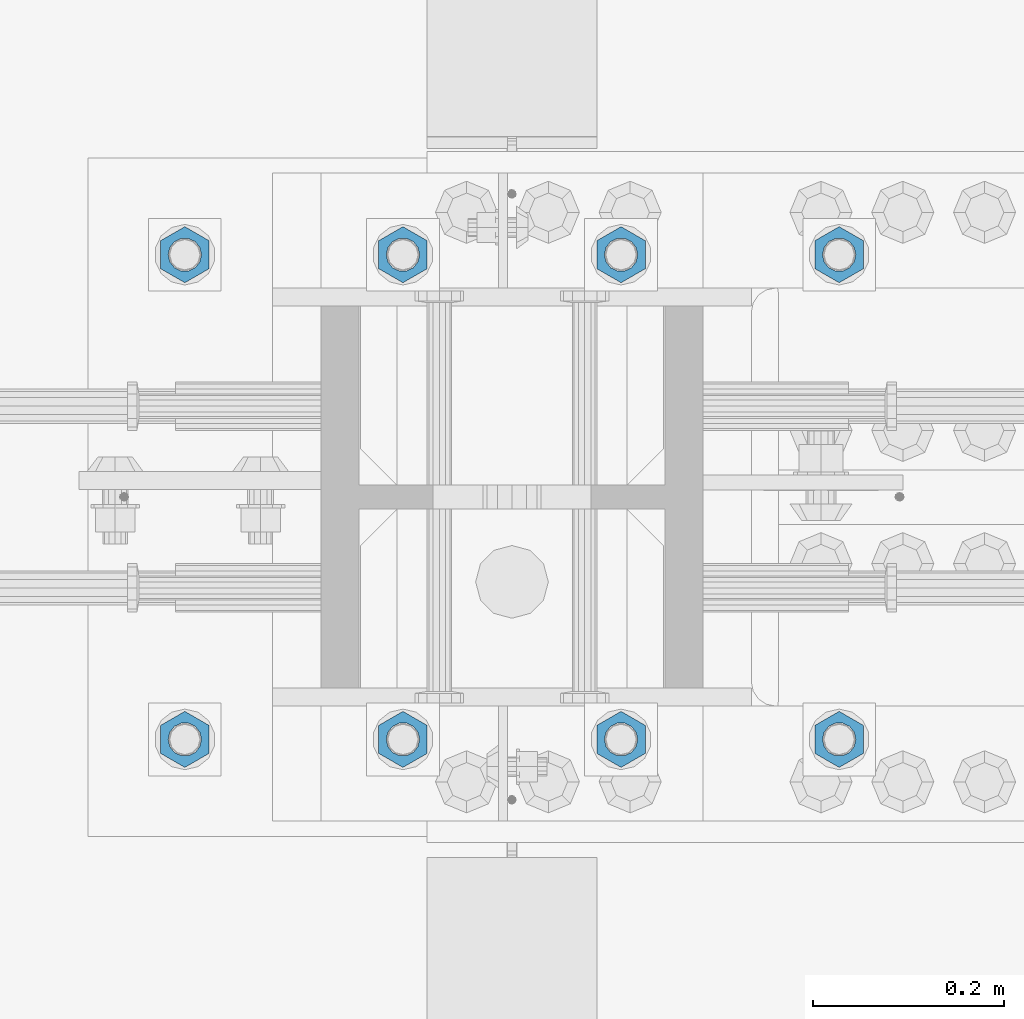
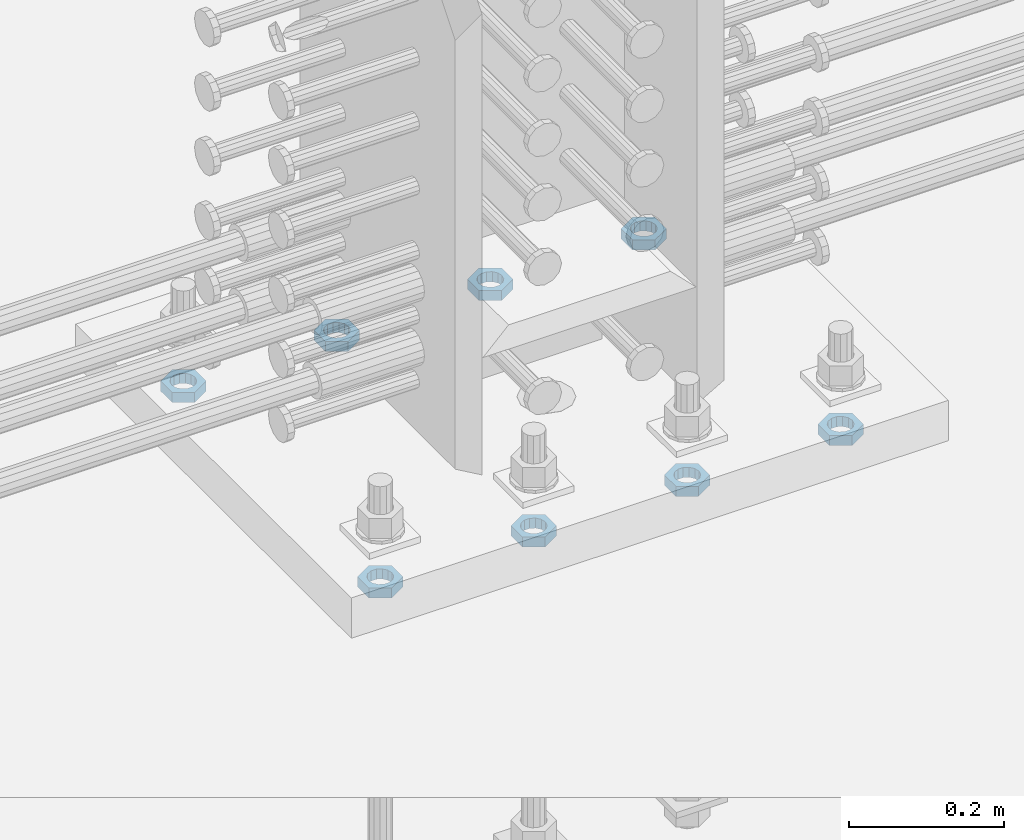
# One storey, part 1392 of 1763: 8 beams, 1 element without a shape of its own.
"""IFC2X3 building model written with IfcOpenShell, lengths in millimetres."""

from ifc_helpers import new_model, si_unit, frame, origin_with_axes, place, context, subcontext, project, spatial, faceted_brep, material, type_object, element, aggregate, save


model = new_model("IFC2X3")

# Units and contexts
model_context = context("Model", 3, precision=1e-05, world=origin_with_axes())
body_context = subcontext(model_context, "Body", "Model", "MODEL_VIEW")
ifc_project = project(units=[si_unit("LENGTHUNIT", "METRE", prefix="MILLI"), si_unit("AREAUNIT", "SQUARE_METRE"), si_unit("VOLUMEUNIT", "CUBIC_METRE"), si_unit("MASSUNIT", "GRAM", prefix="KILO"), si_unit("TIMEUNIT", "SECOND"), si_unit("PLANEANGLEUNIT", "RADIAN"), si_unit("SOLIDANGLEUNIT", "STERADIAN"), si_unit("THERMODYNAMICTEMPERATUREUNIT", "DEGREE_CELSIUS"), si_unit("LUMINOUSINTENSITYUNIT", "LUMEN")], contexts=[model_context])

# Site, building, storey
site_placement = place(None, origin_with_axes())
site = spatial("IfcSite", under=ifc_project, at=site_placement, CompositionType="ELEMENT")
building_placement = place(site_placement, origin_with_axes())
building = spatial("IfcBuilding", under=site, at=building_placement, Name="Undefined", CompositionType="ELEMENT")
storey_placement = place(building_placement, origin_with_axes())
storey = spatial("IfcBuildingStorey", under=building, at=storey_placement, Name="Undefined", CompositionType="ELEMENT", Elevation=0.0)

# Assembly, beams
assembly_placement = place(storey_placement, origin_with_axes())
assembly = element("IfcElementAssembly", 1, at=assembly_placement, inside=storey, Name="TEMPLATE", AssemblyPlace="NOTDEFINED", PredefinedType="RIGID_FRAME")
ifc_material = material(Name="STEEL/A563")
beam_type = type_object("IfcBeamType", Name="1-1/4_DIA. HALF_NUT", PredefinedType="NOTDEFINED")
beam_1_placement = place(assembly_placement, frame((-72833.9372736972, 711.200000000843, 3848.1), z_axis=(-1.0, 0.0, 0.0), x_axis=(0.0, 0.0, -1.0)))
beam_1 = element("IfcBeam", 2, at=beam_1_placement, type_object=beam_type, material=ifc_material, Name="NUT", ObjectType="1-1/4_DIA. HALF_NUT", context=body_context, shape_type="Brep", body=[
    faceted_brep([(0.0, -29.3700008392334, 0.0), (0.0, -14.6800003051758, -25.4300003051758), (15.875, -14.6800003051758, -25.4300003051758), (15.875, -29.3700008392334, 0.0), (0.0, 14.6800003051758, -25.4300003051758), (15.875, 14.6800003051758, -25.4300003051758), (0.0, 29.3700008392334, 0.0), (15.875, 29.3700008392334, 0.0), (0.0, 14.6800003051758, 25.4300003051758), (15.875, 14.6800003051758, 25.4300003051758), (0.0, -14.6800003051758, 25.4300003051758), (15.875, -14.6800003051758, 25.4300003051758), (0.0, 0.0, 17.4599990844727), (0.0, 7.57560968776022, 15.730915608714), (15.875, 7.57560968776022, 15.730915608714), (15.875, 0.0, 17.4599990844727), (0.0, 13.6507769681037, 10.8861313696252), (15.875, 13.6507769681037, 10.8861313696252), (0.0, 17.0222404541215, 3.88521530314756), (15.875, 17.0222404541215, 3.88521530314756), (0.0, 17.0222404541215, -3.88521530314756), (15.875, 17.0222404541215, -3.88521530314756), (0.0, 13.6507769681037, -10.8861313696252), (15.875, 13.6507769681037, -10.8861313696252), (0.0, 7.57560968776022, -15.730915608714), (15.875, 7.57560968776022, -15.730915608714), (0.0, 0.0, -17.4599990844727), (15.875, 0.0, -17.4599990844727), (0.0, -7.57560968776022, -15.730915608714), (15.875, -7.57560968776022, -15.730915608714), (0.0, -13.6507769681037, -10.8861313696252), (15.875, -13.6507769681037, -10.8861313696252), (0.0, -17.0222404541215, -3.88521530314756), (15.875, -17.0222404541215, -3.88521530314756), (0.0, -17.0222404541215, 3.88521530314756), (15.875, -17.0222404541215, 3.88521530314756), (0.0, -13.6507769681037, 10.8861313696252), (15.875, -13.6507769681037, 10.8861313696252), (0.0, -7.57560968776022, 15.730915608714), (15.875, -7.57560968776022, 15.730915608714)], [[[0, 1, 2, 3]], [[1, 4, 5, 2]], [[4, 6, 7, 5]], [[6, 8, 9, 7]], [[8, 10, 11, 9]], [[10, 0, 3, 11]], [[12, 13, 14, 15]], [[13, 16, 17, 14]], [[16, 18, 19, 17]], [[18, 20, 21, 19]], [[20, 22, 23, 21]], [[22, 24, 25, 23]], [[24, 26, 27, 25]], [[26, 28, 29, 27]], [[28, 30, 31, 29]], [[30, 32, 33, 31]], [[32, 34, 35, 33]], [[34, 36, 37, 35]], [[36, 38, 39, 37]], [[38, 12, 15, 39]], [[5, 7, 9, 11, 3, 2], [17, 19, 21, 23, 25, 27, 29, 31, 33, 35, 37, 39, 15, 14]], [[10, 8, 6, 4, 1, 0], [38, 36, 34, 32, 30, 28, 26, 24, 22, 20, 18, 16, 13, 12]]]),
])
beam_2_placement = place(assembly_placement, frame((-72605.3372736972, 711.200000000843, 3848.1), z_axis=(-1.0, 0.0, 0.0), x_axis=(0.0, 0.0, -1.0)))
beam_2 = element("IfcBeam", 3, at=beam_2_placement, type_object=beam_type, material=ifc_material, Name="NUT", ObjectType="1-1/4_DIA. HALF_NUT", context=body_context, shape_type="Brep", body=[
    faceted_brep([(0.0, -29.3700008392334, 0.0), (0.0, -14.6800003051758, -25.4300003051758), (15.875, -14.6800003051758, -25.4300003051758), (15.875, -29.3700008392334, 0.0), (0.0, 14.6800003051758, -25.4300003051758), (15.875, 14.6800003051758, -25.4300003051758), (0.0, 29.3700008392334, 0.0), (15.875, 29.3700008392334, 0.0), (0.0, 14.6800003051758, 25.4300003051758), (15.875, 14.6800003051758, 25.4300003051758), (0.0, -14.6800003051758, 25.4300003051758), (15.875, -14.6800003051758, 25.4300003051758), (0.0, 0.0, 17.4599990844727), (0.0, 7.57560968776022, 15.730915608714), (15.875, 7.57560968776022, 15.730915608714), (15.875, 0.0, 17.4599990844727), (0.0, 13.6507769681037, 10.8861313696252), (15.875, 13.6507769681037, 10.8861313696252), (0.0, 17.0222404541215, 3.88521530314756), (15.875, 17.0222404541215, 3.88521530314756), (0.0, 17.0222404541215, -3.88521530314756), (15.875, 17.0222404541215, -3.88521530314756), (0.0, 13.6507769681037, -10.8861313696252), (15.875, 13.6507769681037, -10.8861313696252), (0.0, 7.57560968776022, -15.730915608714), (15.875, 7.57560968776022, -15.730915608714), (0.0, 0.0, -17.4599990844727), (15.875, 0.0, -17.4599990844727), (0.0, -7.57560968776022, -15.730915608714), (15.875, -7.57560968776022, -15.730915608714), (0.0, -13.6507769681037, -10.8861313696252), (15.875, -13.6507769681037, -10.8861313696252), (0.0, -17.0222404541215, -3.88521530314756), (15.875, -17.0222404541215, -3.88521530314756), (0.0, -17.0222404541215, 3.88521530314756), (15.875, -17.0222404541215, 3.88521530314756), (0.0, -13.6507769681037, 10.8861313696252), (15.875, -13.6507769681037, 10.8861313696252), (0.0, -7.57560968776022, 15.730915608714), (15.875, -7.57560968776022, 15.730915608714)], [[[0, 1, 2, 3]], [[1, 4, 5, 2]], [[4, 6, 7, 5]], [[6, 8, 9, 7]], [[8, 10, 11, 9]], [[10, 0, 3, 11]], [[12, 13, 14, 15]], [[13, 16, 17, 14]], [[16, 18, 19, 17]], [[18, 20, 21, 19]], [[20, 22, 23, 21]], [[22, 24, 25, 23]], [[24, 26, 27, 25]], [[26, 28, 29, 27]], [[28, 30, 31, 29]], [[30, 32, 33, 31]], [[32, 34, 35, 33]], [[34, 36, 37, 35]], [[36, 38, 39, 37]], [[38, 12, 15, 39]], [[5, 7, 9, 11, 3, 2], [17, 19, 21, 23, 25, 27, 29, 31, 33, 35, 37, 39, 15, 14]], [[10, 8, 6, 4, 1, 0], [38, 36, 34, 32, 30, 28, 26, 24, 22, 20, 18, 16, 13, 12]]]),
])
beam_3_placement = place(assembly_placement, frame((-72376.7372736972, 711.200000000843, 3848.1), z_axis=(-1.0, 0.0, 0.0), x_axis=(0.0, 0.0, -1.0)))
beam_3 = element("IfcBeam", 4, at=beam_3_placement, type_object=beam_type, material=ifc_material, Name="NUT", ObjectType="1-1/4_DIA. HALF_NUT", context=body_context, shape_type="Brep", body=[
    faceted_brep([(0.0, -29.3700008392334, 0.0), (0.0, -14.6800003051758, -25.4300003051758), (15.875, -14.6800003051758, -25.4300003051758), (15.875, -29.3700008392334, 0.0), (0.0, 14.6800003051758, -25.4300003051758), (15.875, 14.6800003051758, -25.4300003051758), (0.0, 29.3700008392334, 0.0), (15.875, 29.3700008392334, 0.0), (0.0, 14.6800003051758, 25.4300003051758), (15.875, 14.6800003051758, 25.4300003051758), (0.0, -14.6800003051758, 25.4300003051758), (15.875, -14.6800003051758, 25.4300003051758), (0.0, 0.0, 17.4599990844727), (0.0, 7.57560968776022, 15.730915608714), (15.875, 7.57560968776022, 15.730915608714), (15.875, 0.0, 17.4599990844727), (0.0, 13.6507769681037, 10.8861313696252), (15.875, 13.6507769681037, 10.8861313696252), (0.0, 17.0222404541215, 3.88521530314756), (15.875, 17.0222404541215, 3.88521530314756), (0.0, 17.0222404541215, -3.88521530314756), (15.875, 17.0222404541215, -3.88521530314756), (0.0, 13.6507769681037, -10.8861313696252), (15.875, 13.6507769681037, -10.8861313696252), (0.0, 7.57560968776022, -15.730915608714), (15.875, 7.57560968776022, -15.730915608714), (0.0, 0.0, -17.4599990844727), (15.875, 0.0, -17.4599990844727), (0.0, -7.57560968776022, -15.730915608714), (15.875, -7.57560968776022, -15.730915608714), (0.0, -13.6507769681037, -10.8861313696252), (15.875, -13.6507769681037, -10.8861313696252), (0.0, -17.0222404541215, -3.88521530314756), (15.875, -17.0222404541215, -3.88521530314756), (0.0, -17.0222404541215, 3.88521530314756), (15.875, -17.0222404541215, 3.88521530314756), (0.0, -13.6507769681037, 10.8861313696252), (15.875, -13.6507769681037, 10.8861313696252), (0.0, -7.57560968776022, 15.730915608714), (15.875, -7.57560968776022, 15.730915608714)], [[[0, 1, 2, 3]], [[1, 4, 5, 2]], [[4, 6, 7, 5]], [[6, 8, 9, 7]], [[8, 10, 11, 9]], [[10, 0, 3, 11]], [[12, 13, 14, 15]], [[13, 16, 17, 14]], [[16, 18, 19, 17]], [[18, 20, 21, 19]], [[20, 22, 23, 21]], [[22, 24, 25, 23]], [[24, 26, 27, 25]], [[26, 28, 29, 27]], [[28, 30, 31, 29]], [[30, 32, 33, 31]], [[32, 34, 35, 33]], [[34, 36, 37, 35]], [[36, 38, 39, 37]], [[38, 12, 15, 39]], [[5, 7, 9, 11, 3, 2], [17, 19, 21, 23, 25, 27, 29, 31, 33, 35, 37, 39, 15, 14]], [[10, 8, 6, 4, 1, 0], [38, 36, 34, 32, 30, 28, 26, 24, 22, 20, 18, 16, 13, 12]]]),
])
beam_4_placement = place(assembly_placement, frame((-72148.1372736972, 711.200000000843, 3848.1), z_axis=(-1.0, 0.0, 0.0), x_axis=(0.0, 0.0, -1.0)))
beam_4 = element("IfcBeam", 5, at=beam_4_placement, type_object=beam_type, material=ifc_material, Name="NUT", ObjectType="1-1/4_DIA. HALF_NUT", context=body_context, shape_type="Brep", body=[
    faceted_brep([(0.0, -29.3700008392334, 0.0), (0.0, -14.6800003051758, -25.4300003051758), (15.875, -14.6800003051758, -25.4300003051758), (15.875, -29.3700008392334, 0.0), (0.0, 14.6800003051758, -25.4300003051758), (15.875, 14.6800003051758, -25.4300003051758), (0.0, 29.3700008392334, 0.0), (15.875, 29.3700008392334, 0.0), (0.0, 14.6800003051758, 25.4300003051758), (15.875, 14.6800003051758, 25.4300003051758), (0.0, -14.6800003051758, 25.4300003051758), (15.875, -14.6800003051758, 25.4300003051758), (0.0, 0.0, 17.4599990844727), (0.0, 7.57560968776022, 15.730915608714), (15.875, 7.57560968776022, 15.730915608714), (15.875, 0.0, 17.4599990844727), (0.0, 13.6507769681037, 10.8861313696252), (15.875, 13.6507769681037, 10.8861313696252), (0.0, 17.0222404541215, 3.88521530314756), (15.875, 17.0222404541215, 3.88521530314756), (0.0, 17.0222404541215, -3.88521530314756), (15.875, 17.0222404541215, -3.88521530314756), (0.0, 13.6507769681037, -10.8861313696252), (15.875, 13.6507769681037, -10.8861313696252), (0.0, 7.57560968776022, -15.730915608714), (15.875, 7.57560968776022, -15.730915608714), (0.0, 0.0, -17.4599990844727), (15.875, 0.0, -17.4599990844727), (0.0, -7.57560968776022, -15.730915608714), (15.875, -7.57560968776022, -15.730915608714), (0.0, -13.6507769681037, -10.8861313696252), (15.875, -13.6507769681037, -10.8861313696252), (0.0, -17.0222404541215, -3.88521530314756), (15.875, -17.0222404541215, -3.88521530314756), (0.0, -17.0222404541215, 3.88521530314756), (15.875, -17.0222404541215, 3.88521530314756), (0.0, -13.6507769681037, 10.8861313696252), (15.875, -13.6507769681037, 10.8861313696252), (0.0, -7.57560968776022, 15.730915608714), (15.875, -7.57560968776022, 15.730915608714)], [[[0, 1, 2, 3]], [[1, 4, 5, 2]], [[4, 6, 7, 5]], [[6, 8, 9, 7]], [[8, 10, 11, 9]], [[10, 0, 3, 11]], [[12, 13, 14, 15]], [[13, 16, 17, 14]], [[16, 18, 19, 17]], [[18, 20, 21, 19]], [[20, 22, 23, 21]], [[22, 24, 25, 23]], [[24, 26, 27, 25]], [[26, 28, 29, 27]], [[28, 30, 31, 29]], [[30, 32, 33, 31]], [[32, 34, 35, 33]], [[34, 36, 37, 35]], [[36, 38, 39, 37]], [[38, 12, 15, 39]], [[5, 7, 9, 11, 3, 2], [17, 19, 21, 23, 25, 27, 29, 31, 33, 35, 37, 39, 15, 14]], [[10, 8, 6, 4, 1, 0], [38, 36, 34, 32, 30, 28, 26, 24, 22, 20, 18, 16, 13, 12]]]),
])
beam_5_placement = place(assembly_placement, frame((-72833.9372736972, 203.200000000843, 3848.1), z_axis=(1.0, 0.0, 0.0), x_axis=(0.0, 0.0, -1.0)))
beam_5 = element("IfcBeam", 6, at=beam_5_placement, type_object=beam_type, material=ifc_material, Name="NUT", ObjectType="1-1/4_DIA. HALF_NUT", context=body_context, shape_type="Brep", body=[
    faceted_brep([(0.0, -29.3700008392334, 0.0), (0.0, -14.6800003051758, -25.4300003051758), (15.875, -14.6800003051758, -25.4300003051758), (15.875, -29.3700008392334, 0.0), (0.0, 14.6800003051758, -25.4300003051758), (15.875, 14.6800003051758, -25.4300003051758), (0.0, 29.3700008392334, 0.0), (15.875, 29.3700008392334, 0.0), (0.0, 14.6800003051758, 25.4300003051758), (15.875, 14.6800003051758, 25.4300003051758), (0.0, -14.6800003051758, 25.4300003051758), (15.875, -14.6800003051758, 25.4300003051758), (0.0, 0.0, 17.4599990844727), (0.0, 7.57560968776022, 15.730915608714), (15.875, 7.57560968776022, 15.730915608714), (15.875, 0.0, 17.4599990844727), (0.0, 13.6507769681037, 10.8861313696252), (15.875, 13.6507769681037, 10.8861313696252), (0.0, 17.0222404541215, 3.88521530314756), (15.875, 17.0222404541215, 3.88521530314756), (0.0, 17.0222404541215, -3.88521530314756), (15.875, 17.0222404541215, -3.88521530314756), (0.0, 13.6507769681037, -10.8861313696252), (15.875, 13.6507769681037, -10.8861313696252), (0.0, 7.57560968776022, -15.730915608714), (15.875, 7.57560968776022, -15.730915608714), (0.0, 0.0, -17.4599990844727), (15.875, 0.0, -17.4599990844727), (0.0, -7.57560968776022, -15.730915608714), (15.875, -7.57560968776022, -15.730915608714), (0.0, -13.6507769681037, -10.8861313696252), (15.875, -13.6507769681037, -10.8861313696252), (0.0, -17.0222404541215, -3.88521530314756), (15.875, -17.0222404541215, -3.88521530314756), (0.0, -17.0222404541215, 3.88521530314756), (15.875, -17.0222404541215, 3.88521530314756), (0.0, -13.6507769681037, 10.8861313696252), (15.875, -13.6507769681037, 10.8861313696252), (0.0, -7.57560968776022, 15.730915608714), (15.875, -7.57560968776022, 15.730915608714)], [[[0, 1, 2, 3]], [[1, 4, 5, 2]], [[4, 6, 7, 5]], [[6, 8, 9, 7]], [[8, 10, 11, 9]], [[10, 0, 3, 11]], [[12, 13, 14, 15]], [[13, 16, 17, 14]], [[16, 18, 19, 17]], [[18, 20, 21, 19]], [[20, 22, 23, 21]], [[22, 24, 25, 23]], [[24, 26, 27, 25]], [[26, 28, 29, 27]], [[28, 30, 31, 29]], [[30, 32, 33, 31]], [[32, 34, 35, 33]], [[34, 36, 37, 35]], [[36, 38, 39, 37]], [[38, 12, 15, 39]], [[5, 7, 9, 11, 3, 2], [17, 19, 21, 23, 25, 27, 29, 31, 33, 35, 37, 39, 15, 14]], [[10, 8, 6, 4, 1, 0], [38, 36, 34, 32, 30, 28, 26, 24, 22, 20, 18, 16, 13, 12]]]),
])
beam_6_placement = place(assembly_placement, frame((-72605.3372736972, 203.200000000843, 3848.1), z_axis=(1.0, 0.0, 0.0), x_axis=(0.0, 0.0, -1.0)))
beam_6 = element("IfcBeam", 7, at=beam_6_placement, type_object=beam_type, material=ifc_material, Name="NUT", ObjectType="1-1/4_DIA. HALF_NUT", context=body_context, shape_type="Brep", body=[
    faceted_brep([(0.0, -29.3700008392334, 0.0), (0.0, -14.6800003051758, -25.4300003051758), (15.875, -14.6800003051758, -25.4300003051758), (15.875, -29.3700008392334, 0.0), (0.0, 14.6800003051758, -25.4300003051758), (15.875, 14.6800003051758, -25.4300003051758), (0.0, 29.3700008392334, 0.0), (15.875, 29.3700008392334, 0.0), (0.0, 14.6800003051758, 25.4300003051758), (15.875, 14.6800003051758, 25.4300003051758), (0.0, -14.6800003051758, 25.4300003051758), (15.875, -14.6800003051758, 25.4300003051758), (0.0, 0.0, 17.4599990844727), (0.0, 7.57560968776022, 15.730915608714), (15.875, 7.57560968776022, 15.730915608714), (15.875, 0.0, 17.4599990844727), (0.0, 13.6507769681037, 10.8861313696252), (15.875, 13.6507769681037, 10.8861313696252), (0.0, 17.0222404541215, 3.88521530314756), (15.875, 17.0222404541215, 3.88521530314756), (0.0, 17.0222404541215, -3.88521530314756), (15.875, 17.0222404541215, -3.88521530314756), (0.0, 13.6507769681037, -10.8861313696252), (15.875, 13.6507769681037, -10.8861313696252), (0.0, 7.57560968776022, -15.730915608714), (15.875, 7.57560968776022, -15.730915608714), (0.0, 0.0, -17.4599990844727), (15.875, 0.0, -17.4599990844727), (0.0, -7.57560968776022, -15.730915608714), (15.875, -7.57560968776022, -15.730915608714), (0.0, -13.6507769681037, -10.8861313696252), (15.875, -13.6507769681037, -10.8861313696252), (0.0, -17.0222404541215, -3.88521530314756), (15.875, -17.0222404541215, -3.88521530314756), (0.0, -17.0222404541215, 3.88521530314756), (15.875, -17.0222404541215, 3.88521530314756), (0.0, -13.6507769681037, 10.8861313696252), (15.875, -13.6507769681037, 10.8861313696252), (0.0, -7.57560968776022, 15.730915608714), (15.875, -7.57560968776022, 15.730915608714)], [[[0, 1, 2, 3]], [[1, 4, 5, 2]], [[4, 6, 7, 5]], [[6, 8, 9, 7]], [[8, 10, 11, 9]], [[10, 0, 3, 11]], [[12, 13, 14, 15]], [[13, 16, 17, 14]], [[16, 18, 19, 17]], [[18, 20, 21, 19]], [[20, 22, 23, 21]], [[22, 24, 25, 23]], [[24, 26, 27, 25]], [[26, 28, 29, 27]], [[28, 30, 31, 29]], [[30, 32, 33, 31]], [[32, 34, 35, 33]], [[34, 36, 37, 35]], [[36, 38, 39, 37]], [[38, 12, 15, 39]], [[5, 7, 9, 11, 3, 2], [17, 19, 21, 23, 25, 27, 29, 31, 33, 35, 37, 39, 15, 14]], [[10, 8, 6, 4, 1, 0], [38, 36, 34, 32, 30, 28, 26, 24, 22, 20, 18, 16, 13, 12]]]),
])
beam_7_placement = place(assembly_placement, frame((-72376.7372736972, 203.200000000843, 3848.1), z_axis=(1.0, 0.0, 0.0), x_axis=(0.0, 0.0, -1.0)))
beam_7 = element("IfcBeam", 8, at=beam_7_placement, type_object=beam_type, material=ifc_material, Name="NUT", ObjectType="1-1/4_DIA. HALF_NUT", context=body_context, shape_type="Brep", body=[
    faceted_brep([(0.0, -29.3700008392334, 0.0), (0.0, -14.6800003051758, -25.4300003051758), (15.875, -14.6800003051758, -25.4300003051758), (15.875, -29.3700008392334, 0.0), (0.0, 14.6800003051758, -25.4300003051758), (15.875, 14.6800003051758, -25.4300003051758), (0.0, 29.3700008392334, 0.0), (15.875, 29.3700008392334, 0.0), (0.0, 14.6800003051758, 25.4300003051758), (15.875, 14.6800003051758, 25.4300003051758), (0.0, -14.6800003051758, 25.4300003051758), (15.875, -14.6800003051758, 25.4300003051758), (0.0, 0.0, 17.4599990844727), (0.0, 7.57560968776022, 15.730915608714), (15.875, 7.57560968776022, 15.730915608714), (15.875, 0.0, 17.4599990844727), (0.0, 13.6507769681037, 10.8861313696252), (15.875, 13.6507769681037, 10.8861313696252), (0.0, 17.0222404541215, 3.88521530314756), (15.875, 17.0222404541215, 3.88521530314756), (0.0, 17.0222404541215, -3.88521530314756), (15.875, 17.0222404541215, -3.88521530314756), (0.0, 13.6507769681037, -10.8861313696252), (15.875, 13.6507769681037, -10.8861313696252), (0.0, 7.57560968776022, -15.730915608714), (15.875, 7.57560968776022, -15.730915608714), (0.0, 0.0, -17.4599990844727), (15.875, 0.0, -17.4599990844727), (0.0, -7.57560968776022, -15.730915608714), (15.875, -7.57560968776022, -15.730915608714), (0.0, -13.6507769681037, -10.8861313696252), (15.875, -13.6507769681037, -10.8861313696252), (0.0, -17.0222404541215, -3.88521530314756), (15.875, -17.0222404541215, -3.88521530314756), (0.0, -17.0222404541215, 3.88521530314756), (15.875, -17.0222404541215, 3.88521530314756), (0.0, -13.6507769681037, 10.8861313696252), (15.875, -13.6507769681037, 10.8861313696252), (0.0, -7.57560968776022, 15.730915608714), (15.875, -7.57560968776022, 15.730915608714)], [[[0, 1, 2, 3]], [[1, 4, 5, 2]], [[4, 6, 7, 5]], [[6, 8, 9, 7]], [[8, 10, 11, 9]], [[10, 0, 3, 11]], [[12, 13, 14, 15]], [[13, 16, 17, 14]], [[16, 18, 19, 17]], [[18, 20, 21, 19]], [[20, 22, 23, 21]], [[22, 24, 25, 23]], [[24, 26, 27, 25]], [[26, 28, 29, 27]], [[28, 30, 31, 29]], [[30, 32, 33, 31]], [[32, 34, 35, 33]], [[34, 36, 37, 35]], [[36, 38, 39, 37]], [[38, 12, 15, 39]], [[5, 7, 9, 11, 3, 2], [17, 19, 21, 23, 25, 27, 29, 31, 33, 35, 37, 39, 15, 14]], [[10, 8, 6, 4, 1, 0], [38, 36, 34, 32, 30, 28, 26, 24, 22, 20, 18, 16, 13, 12]]]),
])
beam_8_placement = place(assembly_placement, frame((-72148.1372736972, 203.200000000843, 3848.1), z_axis=(1.0, 0.0, 0.0), x_axis=(0.0, 0.0, -1.0)))
beam_8 = element("IfcBeam", 9, at=beam_8_placement, type_object=beam_type, material=ifc_material, Name="NUT", ObjectType="1-1/4_DIA. HALF_NUT", context=body_context, shape_type="Brep", body=[
    faceted_brep([(0.0, -29.3700008392334, 0.0), (0.0, -14.6800003051758, -25.4300003051758), (15.875, -14.6800003051758, -25.4300003051758), (15.875, -29.3700008392334, 0.0), (0.0, 14.6800003051758, -25.4300003051758), (15.875, 14.6800003051758, -25.4300003051758), (0.0, 29.3700008392334, 0.0), (15.875, 29.3700008392334, 0.0), (0.0, 14.6800003051758, 25.4300003051758), (15.875, 14.6800003051758, 25.4300003051758), (0.0, -14.6800003051758, 25.4300003051758), (15.875, -14.6800003051758, 25.4300003051758), (0.0, 0.0, 17.4599990844727), (0.0, 7.57560968776022, 15.730915608714), (15.875, 7.57560968776022, 15.730915608714), (15.875, 0.0, 17.4599990844727), (0.0, 13.6507769681037, 10.8861313696252), (15.875, 13.6507769681037, 10.8861313696252), (0.0, 17.0222404541215, 3.88521530314756), (15.875, 17.0222404541215, 3.88521530314756), (0.0, 17.0222404541215, -3.88521530314756), (15.875, 17.0222404541215, -3.88521530314756), (0.0, 13.6507769681037, -10.8861313696252), (15.875, 13.6507769681037, -10.8861313696252), (0.0, 7.57560968776022, -15.730915608714), (15.875, 7.57560968776022, -15.730915608714), (0.0, 0.0, -17.4599990844727), (15.875, 0.0, -17.4599990844727), (0.0, -7.57560968776022, -15.730915608714), (15.875, -7.57560968776022, -15.730915608714), (0.0, -13.6507769681037, -10.8861313696252), (15.875, -13.6507769681037, -10.8861313696252), (0.0, -17.0222404541215, -3.88521530314756), (15.875, -17.0222404541215, -3.88521530314756), (0.0, -17.0222404541215, 3.88521530314756), (15.875, -17.0222404541215, 3.88521530314756), (0.0, -13.6507769681037, 10.8861313696252), (15.875, -13.6507769681037, 10.8861313696252), (0.0, -7.57560968776022, 15.730915608714), (15.875, -7.57560968776022, 15.730915608714)], [[[0, 1, 2, 3]], [[1, 4, 5, 2]], [[4, 6, 7, 5]], [[6, 8, 9, 7]], [[8, 10, 11, 9]], [[10, 0, 3, 11]], [[12, 13, 14, 15]], [[13, 16, 17, 14]], [[16, 18, 19, 17]], [[18, 20, 21, 19]], [[20, 22, 23, 21]], [[22, 24, 25, 23]], [[24, 26, 27, 25]], [[26, 28, 29, 27]], [[28, 30, 31, 29]], [[30, 32, 33, 31]], [[32, 34, 35, 33]], [[34, 36, 37, 35]], [[36, 38, 39, 37]], [[38, 12, 15, 39]], [[5, 7, 9, 11, 3, 2], [17, 19, 21, 23, 25, 27, 29, 31, 33, 35, 37, 39, 15, 14]], [[10, 8, 6, 4, 1, 0], [38, 36, 34, 32, 30, 28, 26, 24, 22, 20, 18, 16, 13, 12]]]),
])
aggregate(assembly, [beam_1, beam_2, beam_3, beam_4, beam_5, beam_6, beam_7, beam_8])

save(model, "model.ifc")
